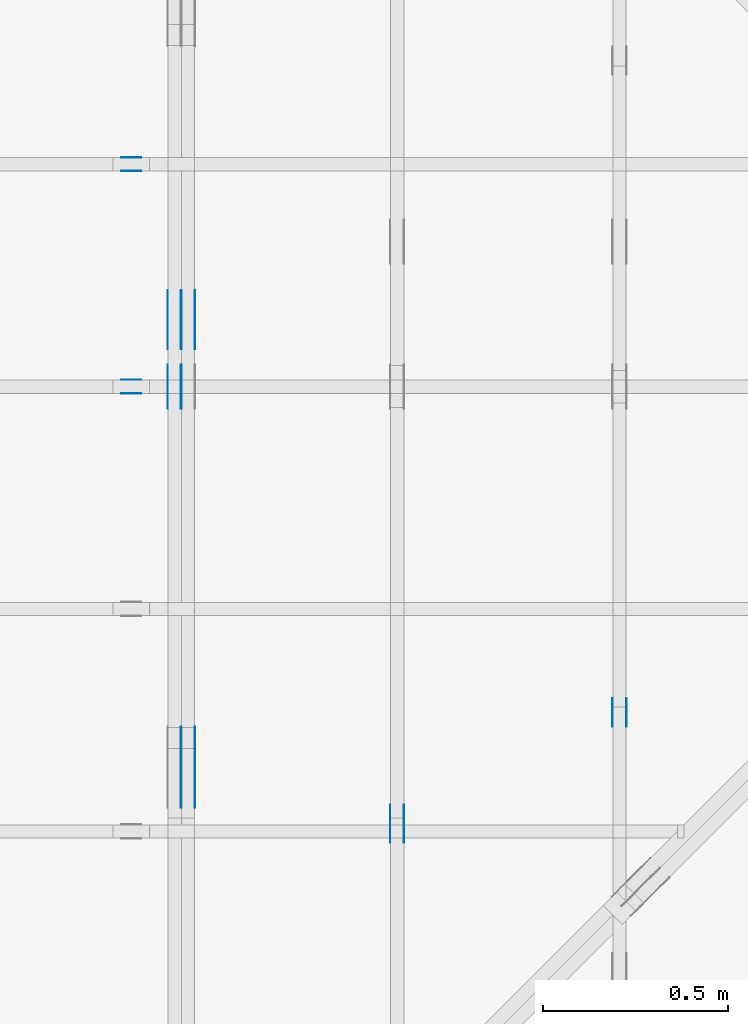
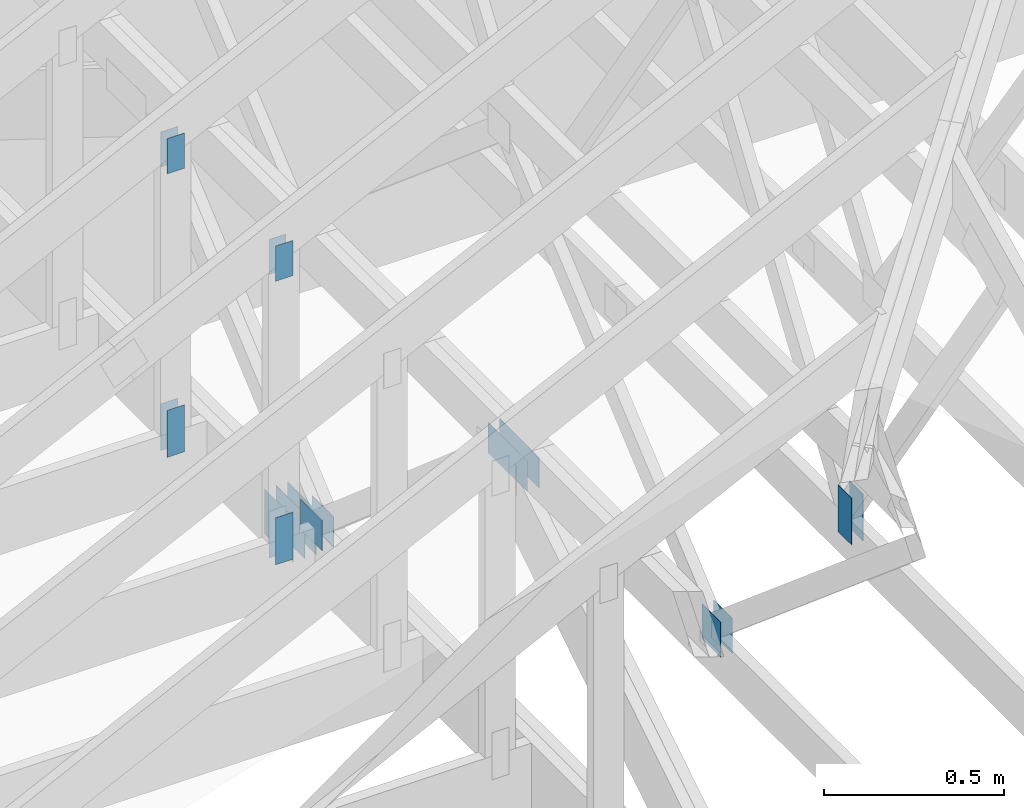
# One storey, part 66 of 159: 21 plates, 5 elements without a shape of their own.
"""IFC2X3 building model written with IfcOpenShell, lengths in millimetres."""

from ifc_helpers import new_model, si_unit, frame, origin, origin_with_axes, origin_2d, place, context, project, spatial, faceted_brep, element, aggregate, save


model = new_model("IFC2X3")

# Units and contexts
model_context = context("Model", 3, precision=1e-05, world=origin())
plan_context = context("Plan", 2, precision=1e-05, world=origin_2d())
ifc_project = project(units=[si_unit("LENGTHUNIT", "METRE", prefix="MILLI"), si_unit("AREAUNIT", "SQUARE_METRE"), si_unit("VOLUMEUNIT", "CUBIC_METRE"), si_unit("SOLIDANGLEUNIT", "STERADIAN"), si_unit("PLANEANGLEUNIT", "RADIAN"), si_unit("MASSUNIT", "GRAM"), si_unit("TIMEUNIT", "SECOND"), si_unit("THERMODYNAMICTEMPERATUREUNIT", "DEGREE_CELSIUS"), si_unit("LUMINOUSINTENSITYUNIT", "LUMEN")], contexts=[model_context, plan_context])

# Site, building, storey
site_placement = place(None, origin_with_axes())
site = spatial("IfcSite", under=ifc_project, at=site_placement, CompositionType="ELEMENT")
building_placement = place(site_placement, origin_with_axes())
building = spatial("IfcBuilding", under=site, at=building_placement, Name="Plan 1", CompositionType="ELEMENT")
storey_placement = place(building_placement, origin_with_axes())
storey = spatial("IfcBuildingStorey", under=building, at=storey_placement, Name="Etasje 1", CompositionType="ELEMENT", Elevation=0.0)

# Assembly, plates
assembly_1_placement = place(storey_placement, frame((-700.000000000007, 4482.000534935255, 1.1021457184401395e-15), z_axis=(0.0, -1.0, 6.123031769111886e-17), x_axis=(1.0, 0.0, 0.0)))
assembly_1 = element("IfcElementAssembly", 1, at=assembly_1_placement, inside=storey, Name="S1 (23)", AssemblyPlace="FACTORY", PredefinedType="TRUSS")
plate_1_placement = place(assembly_1_placement, frame((2503.522261406586, 143.5, 0.0), z_axis=(0.0, 0.0, 1.0), x_axis=(6.123031769111886e-17, 1.0, 0.0)))
plate_1 = element("IfcPlate", 2, at=plate_1_placement, Name="GNT100S 55x159", context=model_context, shape_type="Brep", body=[
    faceted_brep([(159.00000000000003, 55.00004460971104, 1.0), (0.0, 55.00004460971104, 1.0), (0.0, 4.460971103981137e-05, 1.0), (159.00000000000003, 4.460971103981137e-05, 1.0), (0.0, 55.00004460971104, 0.0), (159.00000000000003, 55.00004460971104, 1.94712410257758e-14), (159.00000000000003, 4.460971103981137e-05, 1.94712410257758e-14), (0.0, 4.460971103981137e-05, 0.0), (159.0000000000197, -2.9206861538667314e-14, 1.7883454107731203e-30), (159.0000000000197, -2.9145631220976195e-14, 1.0), (1.9696244635269977e-11, 6.123031768750084e-17, 1.0), (1.9696244635269977e-11, -3.618021949018729e-27, 2.2153263335185782e-43), (159.0000000000197, 55.0, 0.0), (159.0000000000197, 55.0, 1.0), (159.0000000000197, 0.0, 1.0), (159.0000000000197, 0.0, 0.0), (1.9696244635269977e-11, 55.0, 0.0), (1.9696244635269977e-11, 55.0, 1.0), (159.0000000000197, 54.99999999999999, 1.0), (159.0000000000197, 54.99999999999999, -7.888609052210118e-31), (1.9696244635269977e-11, 0.0, 0.0), (1.9696305865587668e-11, -7.498303609110687e-33, 1.0), (1.970304120053369e-11, 55.0, 1.0), (1.9702979970216e-11, 55.0, -4.124066985010878e-31)], [[[0, 1, 2, 3]], [[4, 5, 6, 7]], [[8, 9, 10, 11]], [[12, 13, 14, 15]], [[16, 17, 18, 19]], [[20, 21, 22, 23]]]),
])
plate_2_placement = place(assembly_1_placement, frame((2503.522261406586, 143.5, -37.0), z_axis=(0.0, 0.0, 1.0), x_axis=(6.123031769111886e-17, 1.0, 0.0)))
plate_2 = element("IfcPlate", 3, at=plate_2_placement, Name="GNT100S 55x159", context=model_context, shape_type="Brep", body=[
    faceted_brep([(159.00000000000003, 55.00004460971104, 1.0), (0.0, 55.00004460971104, 1.0), (0.0, 4.460971103981137e-05, 1.0), (159.00000000000003, 4.460971103981137e-05, 1.0), (0.0, 55.00004460971104, 0.0), (159.00000000000003, 55.00004460971104, 1.94712410257758e-14), (159.00000000000003, 4.460971103981137e-05, 1.94712410257758e-14), (0.0, 4.460971103981137e-05, 0.0), (159.0000000000197, -2.9206861538667314e-14, 1.7883454107731203e-30), (159.0000000000197, -2.9145631220976195e-14, 1.0), (1.9696244635269977e-11, 6.123031768750084e-17, 1.0), (1.9696244635269977e-11, -3.618021949018729e-27, 2.2153263335185782e-43), (159.0000000000197, 55.0, 0.0), (159.0000000000197, 55.0, 1.0), (159.0000000000197, 0.0, 1.0), (159.0000000000197, 0.0, 0.0), (1.9696244635269977e-11, 55.0, 0.0), (1.9696244635269977e-11, 55.0, 1.0), (159.0000000000197, 54.99999999999999, 1.0), (159.0000000000197, 54.99999999999999, -7.888609052210118e-31), (1.9696244635269977e-11, 0.0, 0.0), (1.9696305865587668e-11, -7.498303609110687e-33, 1.0), (1.970304120053369e-11, 55.0, 1.0), (1.9702979970216e-11, 55.0, -4.124066985010878e-31)], [[[0, 1, 2, 3]], [[4, 5, 6, 7]], [[8, 9, 10, 11]], [[12, 13, 14, 15]], [[16, 17, 18, 19]], [[20, 21, 22, 23]]]),
])
plate_3_placement = place(assembly_1_placement, frame((2448.522216796875, 1222.4716796875, 0.0), z_axis=(0.0, 0.0, 1.0), x_axis=(6.123031769111886e-17, -1.0, 0.0)))
plate_3 = element("IfcPlate", 4, at=plate_3_placement, Name="GNT100S 55x119", context=model_context, shape_type="Brep", body=[
    faceted_brep([(119.0, 55.0, 1.0), (0.0, 55.0, 1.0), (0.0, 0.0, 1.0), (119.0, 0.0, 1.0), (0.0, 55.0, 0.0), (119.0, 55.0, 1.457281561048629e-14), (119.0, 0.0, 1.457281561048629e-14), (0.0, 0.0, 0.0), (119.00001997564277, 4.460936086249196e-05, 1.3384475843434453e-30), (119.00001997564277, 4.460936086255319e-05, 1.0), (1.9975642771896673e-05, 4.4609360884412414e-05, 1.0), (1.9975642771896673e-05, 4.4609360884351183e-05, 3.76158192263132e-37), (119.00001997564277, 55.000044609360884, 0.0), (119.00001997564277, 55.000044609360884, 1.0), (119.00001997564277, 4.460936088435119e-05, 1.0), (119.00001997564277, 4.460936088435119e-05, 0.0), (1.9975642771896673e-05, 55.000044609360884, 0.0), (1.9975642771896673e-05, 55.000044609360884, 1.0), (119.00001997564277, 55.00004460936088, 1.0), (119.00001997564277, 55.00004460936088, -3.944304526105059e-31), (1.997564277189668e-05, 4.460936088435119e-05, -3.76158192263132e-37), (1.997564277195791e-05, 4.460936088435119e-05, 1.0), (1.9975642778693245e-05, 55.000044609360884, 1.0), (1.9975642778632015e-05, 55.000044609360884, -4.12407052618761e-31)], [[[0, 1, 2, 3]], [[4, 5, 6, 7]], [[8, 9, 10, 11]], [[12, 13, 14, 15]], [[16, 17, 18, 19]], [[20, 21, 22, 23]]]),
])
plate_4_placement = place(assembly_1_placement, frame((2448.522216796875, 1222.4716796875, -37.0), z_axis=(0.0, 0.0, 1.0), x_axis=(6.123031769111886e-17, -1.0, 0.0)))
plate_4 = element("IfcPlate", 5, at=plate_4_placement, Name="GNT100S 55x119", context=model_context, shape_type="Brep", body=[
    faceted_brep([(119.0, 55.0, 1.0), (0.0, 55.0, 1.0), (0.0, 0.0, 1.0), (119.0, 0.0, 1.0), (0.0, 55.0, 0.0), (119.0, 55.0, 1.457281561048629e-14), (119.0, 0.0, 1.457281561048629e-14), (0.0, 0.0, 0.0), (119.00001997564277, 4.460936086249196e-05, 1.3384475843434453e-30), (119.00001997564277, 4.460936086255319e-05, 1.0), (1.9975642771896673e-05, 4.4609360884412414e-05, 1.0), (1.9975642771896673e-05, 4.4609360884351183e-05, 3.76158192263132e-37), (119.00001997564277, 55.000044609360884, 0.0), (119.00001997564277, 55.000044609360884, 1.0), (119.00001997564277, 4.460936088435119e-05, 1.0), (119.00001997564277, 4.460936088435119e-05, 0.0), (1.9975642771896673e-05, 55.000044609360884, 0.0), (1.9975642771896673e-05, 55.000044609360884, 1.0), (119.00001997564277, 55.00004460936088, 1.0), (119.00001997564277, 55.00004460936088, -3.944304526105059e-31), (1.997564277189668e-05, 4.460936088435119e-05, -3.76158192263132e-37), (1.997564277195791e-05, 4.460936088435119e-05, 1.0), (1.9975642778693245e-05, 55.000044609360884, 1.0), (1.9975642778632015e-05, 55.000044609360884, -4.12407052618761e-31)], [[[0, 1, 2, 3]], [[4, 5, 6, 7]], [[8, 9, 10, 11]], [[12, 13, 14, 15]], [[16, 17, 18, 19]], [[20, 21, 22, 23]]]),
])
aggregate(assembly_1, [plate_1, plate_2, plate_3, plate_4])

assembly_2_placement = place(storey_placement, frame((-700.000000000007, 5081.993668449246, 1.1021457184401395e-15), z_axis=(0.0, -1.0, 6.123031769111886e-17), x_axis=(1.0, 0.0, 0.0)))
assembly_2 = element("IfcElementAssembly", 6, at=assembly_2_placement, inside=storey, Name="S2 (15)", AssemblyPlace="FACTORY", PredefinedType="TRUSS")
plate_5_placement = place(assembly_2_placement, frame((2448.522216796875, 1222.4716796875, 0.0), z_axis=(0.0, 0.0, 1.0), x_axis=(6.123031769111886e-17, -1.0, 0.0)))
plate_5 = element("IfcPlate", 7, at=plate_5_placement, Name="GNT100S 55x119", context=model_context, shape_type="Brep", body=[
    faceted_brep([(119.0, 55.0, 1.0), (0.0, 55.0, 1.0), (0.0, 0.0, 1.0), (119.0, 0.0, 1.0), (0.0, 55.0, 0.0), (119.0, 55.0, 1.457281561048629e-14), (119.0, 0.0, 1.457281561048629e-14), (0.0, 0.0, 0.0), (119.00001997548839, 4.460947864205584e-05, 1.3384475843434453e-30), (119.00001997548839, 4.460947864211707e-05, 1.0), (1.9975488385171047e-05, 4.460947866397629e-05, 1.0), (1.9975488385171047e-05, 4.460947866391506e-05, 3.76158192263132e-37), (119.00001997548839, 55.000044609478664, 0.0), (119.00001997548839, 55.000044609478664, 1.0), (119.00001997548839, 4.460947866391507e-05, 1.0), (119.00001997548839, 4.460947866391507e-05, 0.0), (1.9975488385171047e-05, 55.000044609478664, 0.0), (1.9975488385171047e-05, 55.000044609478664, 1.0), (119.00001997548839, 55.00004460947866, 1.0), (119.00001997548839, 55.00004460947866, -3.944304526105059e-31), (1.9975488385171054e-05, 4.460947866391507e-05, -3.76158192263132e-37), (1.9975488385232285e-05, 4.460947866391507e-05, 1.0), (1.997548839196762e-05, 55.000044609478664, 1.0), (1.997548839190639e-05, 55.000044609478664, -4.12407052618761e-31)], [[[0, 1, 2, 3]], [[4, 5, 6, 7]], [[8, 9, 10, 11]], [[12, 13, 14, 15]], [[16, 17, 18, 19]], [[20, 21, 22, 23]]]),
])
plate_6_placement = place(assembly_2_placement, frame((2448.522216796875, 1222.4716796875, -37.0), z_axis=(0.0, 0.0, 1.0), x_axis=(6.123031769111886e-17, -1.0, 0.0)))
plate_6 = element("IfcPlate", 8, at=plate_6_placement, Name="GNT100S 55x119", context=model_context, shape_type="Brep", body=[
    faceted_brep([(119.0, 55.0, 1.0), (0.0, 55.0, 1.0), (0.0, 0.0, 1.0), (119.0, 0.0, 1.0), (0.0, 55.0, 0.0), (119.0, 55.0, 1.457281561048629e-14), (119.0, 0.0, 1.457281561048629e-14), (0.0, 0.0, 0.0), (119.00001997548839, 4.460947864205584e-05, 1.3384475843434453e-30), (119.00001997548839, 4.460947864211707e-05, 1.0), (1.9975488385171047e-05, 4.460947866397629e-05, 1.0), (1.9975488385171047e-05, 4.460947866391506e-05, 3.76158192263132e-37), (119.00001997548839, 55.000044609478664, 0.0), (119.00001997548839, 55.000044609478664, 1.0), (119.00001997548839, 4.460947866391507e-05, 1.0), (119.00001997548839, 4.460947866391507e-05, 0.0), (1.9975488385171047e-05, 55.000044609478664, 0.0), (1.9975488385171047e-05, 55.000044609478664, 1.0), (119.00001997548839, 55.00004460947866, 1.0), (119.00001997548839, 55.00004460947866, -3.944304526105059e-31), (1.9975488385171054e-05, 4.460947866391507e-05, -3.76158192263132e-37), (1.9975488385232285e-05, 4.460947866391507e-05, 1.0), (1.997548839196762e-05, 55.000044609478664, 1.0), (1.997548839190639e-05, 55.000044609478664, -4.12407052618761e-31)], [[[0, 1, 2, 3]], [[4, 5, 6, 7]], [[8, 9, 10, 11]], [[12, 13, 14, 15]], [[16, 17, 18, 19]], [[20, 21, 22, 23]]]),
])
plate_7_placement = place(assembly_2_placement, frame((2503.5222614066006, 143.5, 0.0), z_axis=(0.0, 0.0, 1.0), x_axis=(6.123031769111886e-17, 1.0, 0.0)))
plate_7 = element("IfcPlate", 9, at=plate_7_placement, Name="GNT100S 55x159", context=model_context, shape_type="Brep", body=[
    faceted_brep([(159.00000000000003, 55.00004460972559, 1.0), (0.0, 55.00004460972559, 1.0), (0.0, 4.46097255917266e-05, 1.0), (159.00000000000003, 4.46097255917266e-05, 1.0), (0.0, 55.00004460972559, 0.0), (159.00000000000003, 55.00004460972559, 1.94712410257758e-14), (159.00000000000003, 4.46097255917266e-05, 1.94712410257758e-14), (0.0, 4.46097255917266e-05, 0.0), (159.0000000000197, -2.9206861538667314e-14, 1.7883454107731203e-30), (159.0000000000197, -2.9145631220976195e-14, 1.0), (1.9696244635269977e-11, 6.123031768750084e-17, 1.0), (1.9696244635269977e-11, -3.618021949018729e-27, 2.2153263335185782e-43), (159.0000000000197, 55.0, 0.0), (159.0000000000197, 55.0, 1.0), (159.0000000000197, 0.0, 1.0), (159.0000000000197, 0.0, 0.0), (1.9696244635269977e-11, 55.0, 0.0), (1.9696244635269977e-11, 55.0, 1.0), (159.0000000000197, 54.99999999999999, 1.0), (159.0000000000197, 54.99999999999999, -7.888609052210118e-31), (1.9696244635269977e-11, 0.0, 0.0), (1.9696305865587668e-11, -7.498303609110687e-33, 1.0), (1.970304120053369e-11, 55.0, 1.0), (1.9702979970216e-11, 55.0, -4.124066985010878e-31)], [[[0, 1, 2, 3]], [[4, 5, 6, 7]], [[8, 9, 10, 11]], [[12, 13, 14, 15]], [[16, 17, 18, 19]], [[20, 21, 22, 23]]]),
])
plate_8_placement = place(assembly_2_placement, frame((2503.5222614066006, 143.5, -37.0), z_axis=(0.0, 0.0, 1.0), x_axis=(6.123031769111886e-17, 1.0, 0.0)))
plate_8 = element("IfcPlate", 10, at=plate_8_placement, Name="GNT100S 55x159", context=model_context, shape_type="Brep", body=[
    faceted_brep([(159.00000000000003, 55.00004460972559, 1.0), (0.0, 55.00004460972559, 1.0), (0.0, 4.46097255917266e-05, 1.0), (159.00000000000003, 4.46097255917266e-05, 1.0), (0.0, 55.00004460972559, 0.0), (159.00000000000003, 55.00004460972559, 1.94712410257758e-14), (159.00000000000003, 4.46097255917266e-05, 1.94712410257758e-14), (0.0, 4.46097255917266e-05, 0.0), (159.0000000000197, -2.9206861538667314e-14, 1.7883454107731203e-30), (159.0000000000197, -2.9145631220976195e-14, 1.0), (1.9696244635269977e-11, 6.123031768750084e-17, 1.0), (1.9696244635269977e-11, -3.618021949018729e-27, 2.2153263335185782e-43), (159.0000000000197, 55.0, 0.0), (159.0000000000197, 55.0, 1.0), (159.0000000000197, 0.0, 1.0), (159.0000000000197, 0.0, 0.0), (1.9696244635269977e-11, 55.0, 0.0), (1.9696244635269977e-11, 55.0, 1.0), (159.0000000000197, 54.99999999999999, 1.0), (159.0000000000197, 54.99999999999999, -7.888609052210118e-31), (1.9696244635269977e-11, 0.0, 0.0), (1.9696305865587668e-11, -7.498303609110687e-33, 1.0), (1.970304120053369e-11, 55.0, 1.0), (1.9702979970216e-11, 55.0, -4.124066985010878e-31)], [[[0, 1, 2, 3]], [[4, 5, 6, 7]], [[8, 9, 10, 11]], [[12, 13, 14, 15]], [[16, 17, 18, 19]], [[20, 21, 22, 23]]]),
])
aggregate(assembly_2, [plate_5, plate_6, plate_7, plate_8])

assembly_3_placement = place(storey_placement, frame((3075.02226140475, 9699.999999999993, 1.1021457184401395e-15), z_axis=(-1.0, 1.836909530733566e-16, 6.123031769111886e-17), x_axis=(-1.836909530733566e-16, -1.0, 0.0)))
assembly_3 = element("IfcElementAssembly", 11, at=assembly_3_placement, inside=storey, Name="V3 (4)", AssemblyPlace="FACTORY", PredefinedType="TRUSS")
plate_9_placement = place(assembly_3_placement, frame((6117.210551169496, 291.5, 0.0), z_axis=(0.0, 0.0, 1.0), x_axis=(6.123031769111886e-17, 1.0, 0.0)))
plate_9 = element("IfcPlate", 12, at=plate_9_placement, Name="GNT100S 76x159", context=model_context, shape_type="Brep", body=[
    faceted_brep([(159.0, 76.00010195074628, 1.0), (0.0, 76.00010195074628, 1.0), (0.0, 0.00010195074628427392, 1.0), (159.0, 0.00010195074628427392, 1.0), (0.0, 76.00010195074628, 0.0), (159.0, 76.00010195074628, 1.9471241025775798e-14), (159.0, 0.00010195074628427392, 1.9471241025775798e-14), (0.0, 0.00010195074628427392, 0.0), (159.0000000000004, -2.9206861538663773e-14, 1.7883454107729035e-30), (159.0000000000004, -2.9145631220972654e-14, 1.0), (3.979039320256561e-13, 6.123031769104577e-17, 1.0), (3.979039320256561e-13, -7.309135250542887e-29, 4.475406734380966e-45), (159.0000000000004, 76.0, 0.0), (159.0000000000004, 76.0, 1.0), (159.0000000000004, 0.0, 1.0), (159.0000000000004, 0.0, 0.0), (3.979039320256561e-13, 76.0, 0.0), (3.979039320256561e-13, 76.0, 1.0), (159.0000000000004, 75.99999999999999, 1.0), (159.0000000000004, 75.99999999999999, -7.888609052210118e-31), (3.979039320256561e-13, 0.0, 0.0), (3.979651623433472e-13, -7.498303609110687e-33, 1.0), (4.072721706323973e-13, 76.0, 1.0), (4.0721094031470617e-13, 76.0, -5.698710742924122e-31)], [[[0, 1, 2, 3]], [[4, 5, 6, 7]], [[8, 9, 10, 11]], [[12, 13, 14, 15]], [[16, 17, 18, 19]], [[20, 21, 22, 23]]]),
])
plate_10_placement = place(assembly_3_placement, frame((6117.210551169496, 291.5, -37.0), z_axis=(0.0, 0.0, 1.0), x_axis=(6.123031769111886e-17, 1.0, 0.0)))
plate_10 = element("IfcPlate", 13, at=plate_10_placement, Name="GNT100S 76x159", context=model_context, shape_type="Brep", body=[
    faceted_brep([(159.0, 76.00010195074628, 1.0), (0.0, 76.00010195074628, 1.0), (0.0, 0.00010195074628427392, 1.0), (159.0, 0.00010195074628427392, 1.0), (0.0, 76.00010195074628, 0.0), (159.0, 76.00010195074628, 1.9471241025775798e-14), (159.0, 0.00010195074628427392, 1.9471241025775798e-14), (0.0, 0.00010195074628427392, 0.0), (159.0000000000004, -2.9206861538663773e-14, 1.7883454107729035e-30), (159.0000000000004, -2.9145631220972654e-14, 1.0), (3.979039320256561e-13, 6.123031769104577e-17, 1.0), (3.979039320256561e-13, -7.309135250542887e-29, 4.475406734380966e-45), (159.0000000000004, 76.0, 0.0), (159.0000000000004, 76.0, 1.0), (159.0000000000004, 0.0, 1.0), (159.0000000000004, 0.0, 0.0), (3.979039320256561e-13, 76.0, 0.0), (3.979039320256561e-13, 76.0, 1.0), (159.0000000000004, 75.99999999999999, 1.0), (159.0000000000004, 75.99999999999999, -7.888609052210118e-31), (3.979039320256561e-13, 0.0, 0.0), (3.979651623433472e-13, -7.498303609110687e-33, 1.0), (4.072721706323973e-13, 76.0, 1.0), (4.0721094031470617e-13, 76.0, -5.698710742924122e-31)], [[[0, 1, 2, 3]], [[4, 5, 6, 7]], [[8, 9, 10, 11]], [[12, 13, 14, 15]], [[16, 17, 18, 19]], [[20, 21, 22, 23]]]),
])
aggregate(assembly_3, [plate_9, plate_10])

assembly_4_placement = place(storey_placement, frame((2475.02226140475, 9699.999999999993, 1.1021457184401395e-15), z_axis=(-1.0, 1.836909530733566e-16, 6.123031769111886e-17), x_axis=(-1.836909530733566e-16, -1.0, 0.0)))
assembly_4 = element("IfcElementAssembly", 14, at=assembly_4_placement, inside=storey, Name="V2 (3)", AssemblyPlace="FACTORY", PredefinedType="TRUSS")
plate_11_placement = place(assembly_4_placement, frame((6430.710551169639, 311.49999999999983, 0.0), z_axis=(0.0, 0.0, 1.0), x_axis=(6.123031769111886e-17, 1.0, 0.0)))
plate_11 = element("IfcPlate", 15, at=plate_11_placement, Name="GNT100S 103x119", context=model_context, shape_type="Brep", body=[
    faceted_brep([(119.00000000000017, 103.00010195088907, 1.0), (1.7053025658242404e-13, 103.00010195088907, 1.0), (1.7053025658242404e-13, 0.0001019508890749421, 1.0), (119.00000000000017, 0.0001019508890749421, 1.0), (1.7053025658242404e-13, 103.00010195088907, 2.0883243572979676e-29), (119.00000000000017, 103.00010195088907, 1.457281561048631e-14), (119.00000000000017, 0.0001019508890749421, 1.457281561048631e-14), (1.7053025658242404e-13, 0.0001019508890749421, 2.0883243572979676e-29), (119.0, -2.1859223415729434e-14, 1.3384471942262577e-30), (119.0, -2.1797993098038315e-14, 1.0), (1.1247455413666031e-32, 6.123031769111886e-17, 1.0), (0.0, 0.0, 0.0), (119.0, 103.0, 0.0), (119.0, 103.0, 1.0), (119.0, 0.0, 1.0), (119.0, 0.0, 0.0), (0.0, 103.0, 0.0), (-3.7491518045553436e-33, 103.0, 1.0), (119.0, 102.99999999999999, 1.0), (119.0, 102.99999999999999, -7.888609052210118e-31), (0.0, 0.0, 0.0), (6.123031769111886e-17, -7.498303609110687e-33, 1.0), (1.2674675762061605e-14, 103.0, 1.0), (1.2613445444370486e-14, 103.0, -7.723252717384008e-31)], [[[0, 1, 2, 3]], [[4, 5, 6, 7]], [[8, 9, 10, 11]], [[12, 13, 14, 15]], [[16, 17, 18, 19]], [[20, 21, 22, 23]]]),
])
plate_12_placement = place(assembly_4_placement, frame((6430.710551169639, 311.49999999999983, -37.0), z_axis=(0.0, 0.0, 1.0), x_axis=(6.123031769111886e-17, 1.0, 0.0)))
plate_12 = element("IfcPlate", 16, at=plate_12_placement, Name="GNT100S 103x119", context=model_context, shape_type="Brep", body=[
    faceted_brep([(119.00000000000017, 103.00010195088907, 1.0), (1.7053025658242404e-13, 103.00010195088907, 1.0), (1.7053025658242404e-13, 0.0001019508890749421, 1.0), (119.00000000000017, 0.0001019508890749421, 1.0), (1.7053025658242404e-13, 103.00010195088907, 2.0883243572979676e-29), (119.00000000000017, 103.00010195088907, 1.457281561048631e-14), (119.00000000000017, 0.0001019508890749421, 1.457281561048631e-14), (1.7053025658242404e-13, 0.0001019508890749421, 2.0883243572979676e-29), (119.0, -2.1859223415729434e-14, 1.3384471942262577e-30), (119.0, -2.1797993098038315e-14, 1.0), (1.1247455413666031e-32, 6.123031769111886e-17, 1.0), (0.0, 0.0, 0.0), (119.0, 103.0, 0.0), (119.0, 103.0, 1.0), (119.0, 0.0, 1.0), (119.0, 0.0, 0.0), (0.0, 103.0, 0.0), (-3.7491518045553436e-33, 103.0, 1.0), (119.0, 102.99999999999999, 1.0), (119.0, 102.99999999999999, -7.888609052210118e-31), (0.0, 0.0, 0.0), (6.123031769111886e-17, -7.498303609110687e-33, 1.0), (1.2674675762061605e-14, 103.0, 1.0), (1.2613445444370486e-14, 103.0, -7.723252717384008e-31)], [[[0, 1, 2, 3]], [[4, 5, 6, 7]], [[8, 9, 10, 11]], [[12, 13, 14, 15]], [[16, 17, 18, 19]], [[20, 21, 22, 23]]]),
])
aggregate(assembly_4, [plate_11, plate_12])

assembly_5_placement = place(storey_placement, frame((1875.0222614047502, 9699.999999999993, 0.0), z_axis=(-1.0, 1.836909530733566e-16, 6.123031769111886e-17), x_axis=(-1.836909530733566e-16, -1.0, 0.0)))
assembly_5 = element("IfcElementAssembly", 17, at=assembly_5_placement, inside=storey, Name="V1 (2)", AssemblyPlace="FACTORY", PredefinedType="TRUSS")
plate_13_placement = place(assembly_5_placement, frame((6117.8147670622475, 1011.7571859793313, -36.0), z_axis=(0.0, 0.0, 1.0), x_axis=(1.0, 0.0, 0.0)))
plate_13 = element("IfcPlate", 18, at=plate_13_placement, Name="GNT100S 103x218", context=model_context, shape_type="Brep", body=[
    faceted_brep([(218.00017434400252, 103.00001616910617, 1.0), (0.000174344002516591, 103.00001616910617, 1.0), (0.000174344002516591, 1.6169106174857006e-05, 1.0), (218.00017434400252, 1.6169106174857006e-05, 1.0), (0.000174344002516591, 103.00001616910617, 2.1350277323264186e-20), (218.00017434400252, 103.00001616910617, 2.6696439863605148e-14), (218.00017434400252, 1.6169106174857006e-05, 2.6696439863605148e-14), (0.000174344002516591, 1.6169106174857006e-05, 2.1350277323264186e-20), (218.0, -4.0044627769991736e-14, 2.4519452801791947e-30), (218.0, -3.998339745230062e-14, 1.0), (1.1247455413666031e-32, 6.123031769111886e-17, 1.0), (0.0, 0.0, 0.0), (218.0, 103.0, 0.0), (218.0, 103.0, 1.0), (218.0, 0.0, 1.0), (218.0, 0.0, 0.0), (0.0, 103.0, 0.0), (-3.7491518045553436e-33, 103.0, 1.0), (218.0, 102.99999999999999, 1.0), (218.0, 102.99999999999999, -7.888609052210118e-31), (0.0, 0.0, 0.0), (6.123031769111886e-17, -7.498303609110687e-33, 1.0), (1.2674675762061605e-14, 103.0, 1.0), (1.2613445444370486e-14, 103.0, -7.723252717384008e-31)], [[[0, 1, 2, 3]], [[4, 5, 6, 7]], [[8, 9, 10, 11]], [[12, 13, 14, 15]], [[16, 17, 18, 19]], [[20, 21, 22, 23]]]),
])
plate_14_placement = place(assembly_5_placement, frame((6117.8147670622475, 1011.7571859793313, -73.0), z_axis=(0.0, 0.0, 1.0), x_axis=(1.0, 0.0, 0.0)))
plate_14 = element("IfcPlate", 19, at=plate_14_placement, Name="GNT100S 103x218", context=model_context, shape_type="Brep", body=[
    faceted_brep([(218.00017434400252, 103.00001616910617, 1.0), (0.000174344002516591, 103.00001616910617, 1.0), (0.000174344002516591, 1.6169106174857006e-05, 1.0), (218.00017434400252, 1.6169106174857006e-05, 1.0), (0.000174344002516591, 103.00001616910617, 2.1350277323264186e-20), (218.00017434400252, 103.00001616910617, 2.6696439863605148e-14), (218.00017434400252, 1.6169106174857006e-05, 2.6696439863605148e-14), (0.000174344002516591, 1.6169106174857006e-05, 2.1350277323264186e-20), (218.0, -4.0044627769991736e-14, 2.4519452801791947e-30), (218.0, -3.998339745230062e-14, 1.0), (1.1247455413666031e-32, 6.123031769111886e-17, 1.0), (0.0, 0.0, 0.0), (218.0, 103.0, 0.0), (218.0, 103.0, 1.0), (218.0, 0.0, 1.0), (218.0, 0.0, 0.0), (0.0, 103.0, 0.0), (-3.7491518045553436e-33, 103.0, 1.0), (218.0, 102.99999999999999, 1.0), (218.0, 102.99999999999999, -7.888609052210118e-31), (0.0, 0.0, 0.0), (6.123031769111886e-17, -7.498303609110687e-33, 1.0), (1.2674675762061605e-14, 103.0, 1.0), (1.2613445444370486e-14, 103.0, -7.723252717384008e-31)], [[[0, 1, 2, 3]], [[4, 5, 6, 7]], [[8, 9, 10, 11]], [[12, 13, 14, 15]], [[16, 17, 18, 19]], [[20, 21, 22, 23]]]),
])
plate_15_placement = place(assembly_5_placement, frame((5099.4990234375, 187.5, 0.0), z_axis=(0.0, 0.0, 1.0), x_axis=(-1.0, 1.2246063538223773e-16, 0.0)))
plate_15 = element("IfcPlate", 20, at=plate_15_placement, Name="GNT100S 152x159", context=model_context, shape_type="Brep", body=[
    faceted_brep([(159.0, 152.0, 1.0), (0.0, 152.0, 1.0), (0.0, 0.0, 1.0), (159.0, 0.0, 1.0), (0.0, 152.0, 0.0), (159.0, 152.0, 1.9471241025775798e-14), (159.0, 2.842170943040401e-14, 1.9471241025775798e-14), (0.0, 2.842170943040401e-14, 0.0), (159.00012207031978, -2.920688396187708e-14, 1.788346783753378e-30), (159.00012207031978, -2.914565364418596e-14, 1.0), (0.00012207031977595761, 6.120789447773725e-17, 1.0), (0.00012207031977595761, -2.2423213381615063e-20, 1.372980479012038e-36), (159.00012207031978, 152.0, 0.0), (159.00012207031978, 152.0, 1.0), (159.00012207031978, 0.0, 1.0), (159.00012207031978, 0.0, 0.0), (0.00012207031977595761, 152.0, 0.0), (0.00012207031977595761, 152.0, 1.0), (159.00012207031978, 152.0, 1.0), (159.00012207031978, 152.0, 0.0), (0.00012207031977595761, 0.0, 0.0), (0.00012207031977601884, -7.498303609110687e-33, 1.0), (0.00012207031979463286, 152.0, 1.0), (0.00012207031979457163, 152.0, -1.1397427715968304e-30)], [[[0, 1, 2, 3]], [[4, 5, 6, 7]], [[8, 9, 10, 11]], [[12, 13, 14, 15]], [[16, 17, 18, 19]], [[20, 21, 22, 23]]]),
])
plate_16_placement = place(assembly_5_placement, frame((5099.4990234375, 187.5, -37.0), z_axis=(0.0, 0.0, 1.0), x_axis=(-1.0, 1.2246063538223773e-16, 0.0)))
plate_16 = element("IfcPlate", 21, at=plate_16_placement, Name="GNT100S 152x159", context=model_context, shape_type="Brep", body=[
    faceted_brep([(159.0, 152.0, 1.0), (0.0, 152.0, 1.0), (0.0, 0.0, 1.0), (159.0, 0.0, 1.0), (0.0, 152.0, 0.0), (159.0, 152.0, 1.9471241025775798e-14), (159.0, 2.842170943040401e-14, 1.9471241025775798e-14), (0.0, 2.842170943040401e-14, 0.0), (159.00012207031978, -2.920688396187708e-14, 1.788346783753378e-30), (159.00012207031978, -2.914565364418596e-14, 1.0), (0.00012207031977595761, 6.120789447773725e-17, 1.0), (0.00012207031977595761, -2.2423213381615063e-20, 1.372980479012038e-36), (159.00012207031978, 152.0, 0.0), (159.00012207031978, 152.0, 1.0), (159.00012207031978, 0.0, 1.0), (159.00012207031978, 0.0, 0.0), (0.00012207031977595761, 152.0, 0.0), (0.00012207031977595761, 152.0, 1.0), (159.00012207031978, 152.0, 1.0), (159.00012207031978, 152.0, 0.0), (0.00012207031977595761, 0.0, 0.0), (0.00012207031977601884, -7.498303609110687e-33, 1.0), (0.00012207031979463286, 152.0, 1.0), (0.00012207031979457163, 152.0, -1.1397427715968304e-30)], [[[0, 1, 2, 3]], [[4, 5, 6, 7]], [[8, 9, 10, 11]], [[12, 13, 14, 15]], [[16, 17, 18, 19]], [[20, 21, 22, 23]]]),
])
plate_17_placement = place(assembly_5_placement, frame((5099.4990234375, 187.5, -36.0), z_axis=(0.0, 0.0, 1.0), x_axis=(-1.0, 1.2246063538223773e-16, 0.0)))
plate_17 = element("IfcPlate", 22, at=plate_17_placement, Name="GNT100S 152x159", context=model_context, shape_type="Brep", body=[
    faceted_brep([(159.0, 152.0, 1.0), (0.0, 152.0, 1.0), (0.0, 0.0, 1.0), (159.0, 0.0, 1.0), (0.0, 152.0, 0.0), (159.0, 152.0, 1.9471241025775798e-14), (159.0, 2.842170943040401e-14, 1.9471241025775798e-14), (0.0, 2.842170943040401e-14, 0.0), (159.00012207031978, -2.920688396187708e-14, 1.788346783753378e-30), (159.00012207031978, -2.914565364418596e-14, 1.0), (0.00012207031977595761, 6.120789447773725e-17, 1.0), (0.00012207031977595761, -2.2423213381615063e-20, 1.372980479012038e-36), (159.00012207031978, 152.0, 0.0), (159.00012207031978, 152.0, 1.0), (159.00012207031978, 0.0, 1.0), (159.00012207031978, 0.0, 0.0), (0.00012207031977595761, 152.0, 0.0), (0.00012207031977595761, 152.0, 1.0), (159.00012207031978, 152.0, 1.0), (159.00012207031978, 152.0, 0.0), (0.00012207031977595761, 0.0, 0.0), (0.00012207031977601884, -7.498303609110687e-33, 1.0), (0.00012207031979463286, 152.0, 1.0), (0.00012207031979457163, 152.0, -1.1397427715968304e-30)], [[[0, 1, 2, 3]], [[4, 5, 6, 7]], [[8, 9, 10, 11]], [[12, 13, 14, 15]], [[16, 17, 18, 19]], [[20, 21, 22, 23]]]),
])
plate_18_placement = place(assembly_5_placement, frame((5099.4990234375, 187.5, -73.0), z_axis=(0.0, 0.0, 1.0), x_axis=(-1.0, 1.2246063538223773e-16, 0.0)))
plate_18 = element("IfcPlate", 23, at=plate_18_placement, Name="GNT100S 152x159", context=model_context, shape_type="Brep", body=[
    faceted_brep([(159.0, 152.0, 1.0), (0.0, 152.0, 1.0), (0.0, 0.0, 1.0), (159.0, 0.0, 1.0), (0.0, 152.0, 0.0), (159.0, 152.0, 1.9471241025775798e-14), (159.0, 2.842170943040401e-14, 1.9471241025775798e-14), (0.0, 2.842170943040401e-14, 0.0), (159.00012207031978, -2.920688396187708e-14, 1.788346783753378e-30), (159.00012207031978, -2.914565364418596e-14, 1.0), (0.00012207031977595761, 6.120789447773725e-17, 1.0), (0.00012207031977595761, -2.2423213381615063e-20, 1.372980479012038e-36), (159.00012207031978, 152.0, 0.0), (159.00012207031978, 152.0, 1.0), (159.00012207031978, 0.0, 1.0), (159.00012207031978, 0.0, 0.0), (0.00012207031977595761, 152.0, 0.0), (0.00012207031977595761, 152.0, 1.0), (159.00012207031978, 152.0, 1.0), (159.00012207031978, 152.0, 0.0), (0.00012207031977595761, 0.0, 0.0), (0.00012207031977601884, -7.498303609110687e-33, 1.0), (0.00012207031979463286, 152.0, 1.0), (0.00012207031979457163, 152.0, -1.1397427715968304e-30)], [[[0, 1, 2, 3]], [[4, 5, 6, 7]], [[8, 9, 10, 11]], [[12, 13, 14, 15]], [[16, 17, 18, 19]], [[20, 21, 22, 23]]]),
])
plate_19_placement = place(assembly_5_placement, frame((5140.499465065974, 171.5, 0.0), z_axis=(0.0, 0.0, 1.0), x_axis=(1.0, 0.0, 0.0)))
plate_19 = element("IfcPlate", 24, at=plate_19_placement, Name="GNT100S 103x119", context=model_context, shape_type="Brep", body=[
    faceted_brep([(119.00004665277629, 103.0, 1.0), (4.665277629101183e-05, 103.0, 1.0), (4.665277629101183e-05, 0.0, 1.0), (119.00004665277629, 0.0, 1.0), (4.665277629101183e-05, 103.0, 5.713128626942705e-21), (119.00004665277629, 103.0, 1.4572821323614915e-14), (119.00004665277629, 0.0, 1.4572821323614915e-14), (4.665277629101183e-05, 0.0, 5.713128626942705e-21), (119.0, 6.562486014674573e-15, 1.3384471942262577e-30), (119.0, 6.623716332365692e-15, 1.0), (1.1247455413666031e-32, 2.8482939748095126e-14, 1.0), (0.0, 2.842170943040401e-14, 0.0), (119.0, 103.0, 0.0), (119.0, 103.0, 1.0), (119.0, 2.842170943040401e-14, 1.0), (119.0, 2.842170943040401e-14, 0.0), (0.0, 103.0, 0.0), (-3.7491518045553436e-33, 103.0, 1.0), (119.0, 102.99999999999999, 1.0), (119.0, 102.99999999999999, -7.888609052210118e-31), (3.4805405954966126e-30, 2.842170943040401e-14, -2.1311460639909362e-46), (6.123031769112234e-17, 2.842170943040401e-14, 1.0), (1.2674675762061605e-14, 103.0, 1.0), (1.2613445444370486e-14, 103.0, -7.723252717384008e-31)], [[[0, 1, 2, 3]], [[4, 5, 6, 7]], [[8, 9, 10, 11]], [[12, 13, 14, 15]], [[16, 17, 18, 19]], [[20, 21, 22, 23]]]),
])
plate_20_placement = place(assembly_5_placement, frame((5140.499465065974, 171.5, -37.0), z_axis=(0.0, 0.0, 1.0), x_axis=(1.0, 0.0, 0.0)))
plate_20 = element("IfcPlate", 25, at=plate_20_placement, Name="GNT100S 103x119", context=model_context, shape_type="Brep", body=[
    faceted_brep([(119.00004665277629, 103.0, 1.0), (4.665277629101183e-05, 103.0, 1.0), (4.665277629101183e-05, 0.0, 1.0), (119.00004665277629, 0.0, 1.0), (4.665277629101183e-05, 103.0, 5.713128626942705e-21), (119.00004665277629, 103.0, 1.4572821323614915e-14), (119.00004665277629, 0.0, 1.4572821323614915e-14), (4.665277629101183e-05, 0.0, 5.713128626942705e-21), (119.0, 6.562486014674573e-15, 1.3384471942262577e-30), (119.0, 6.623716332365692e-15, 1.0), (1.1247455413666031e-32, 2.8482939748095126e-14, 1.0), (0.0, 2.842170943040401e-14, 0.0), (119.0, 103.0, 0.0), (119.0, 103.0, 1.0), (119.0, 2.842170943040401e-14, 1.0), (119.0, 2.842170943040401e-14, 0.0), (0.0, 103.0, 0.0), (-3.7491518045553436e-33, 103.0, 1.0), (119.0, 102.99999999999999, 1.0), (119.0, 102.99999999999999, -7.888609052210118e-31), (3.4805405954966126e-30, 2.842170943040401e-14, -2.1311460639909362e-46), (6.123031769112234e-17, 2.842170943040401e-14, 1.0), (1.2674675762061605e-14, 103.0, 1.0), (1.2613445444370486e-14, 103.0, -7.723252717384008e-31)], [[[0, 1, 2, 3]], [[4, 5, 6, 7]], [[8, 9, 10, 11]], [[12, 13, 14, 15]], [[16, 17, 18, 19]], [[20, 21, 22, 23]]]),
])
plate_21_placement = place(assembly_5_placement, frame((5140.499465065974, 171.5, -36.0), z_axis=(0.0, 0.0, 1.0), x_axis=(1.0, 0.0, 0.0)))
plate_21 = element("IfcPlate", 26, at=plate_21_placement, Name="GNT100S 103x119", context=model_context, shape_type="Brep", body=[
    faceted_brep([(119.00004665277629, 103.0, 1.0), (4.665277629101183e-05, 103.0, 1.0), (4.665277629101183e-05, 0.0, 1.0), (119.00004665277629, 0.0, 1.0), (4.665277629101183e-05, 103.0, 5.713128626942705e-21), (119.00004665277629, 103.0, 1.4572821323614915e-14), (119.00004665277629, 0.0, 1.4572821323614915e-14), (4.665277629101183e-05, 0.0, 5.713128626942705e-21), (119.0, 6.562486014674573e-15, 1.3384471942262577e-30), (119.0, 6.623716332365692e-15, 1.0), (1.1247455413666031e-32, 2.8482939748095126e-14, 1.0), (0.0, 2.842170943040401e-14, 0.0), (119.0, 103.0, 0.0), (119.0, 103.0, 1.0), (119.0, 2.842170943040401e-14, 1.0), (119.0, 2.842170943040401e-14, 0.0), (0.0, 103.0, 0.0), (-3.7491518045553436e-33, 103.0, 1.0), (119.0, 102.99999999999999, 1.0), (119.0, 102.99999999999999, -7.888609052210118e-31), (3.4805405954966126e-30, 2.842170943040401e-14, -2.1311460639909362e-46), (6.123031769112234e-17, 2.842170943040401e-14, 1.0), (1.2674675762061605e-14, 103.0, 1.0), (1.2613445444370486e-14, 103.0, -7.723252717384008e-31)], [[[0, 1, 2, 3]], [[4, 5, 6, 7]], [[8, 9, 10, 11]], [[12, 13, 14, 15]], [[16, 17, 18, 19]], [[20, 21, 22, 23]]]),
])
aggregate(assembly_5, [plate_13, plate_14, plate_15, plate_16, plate_17, plate_18, plate_19, plate_20, plate_21])

save(model, "model.ifc")
